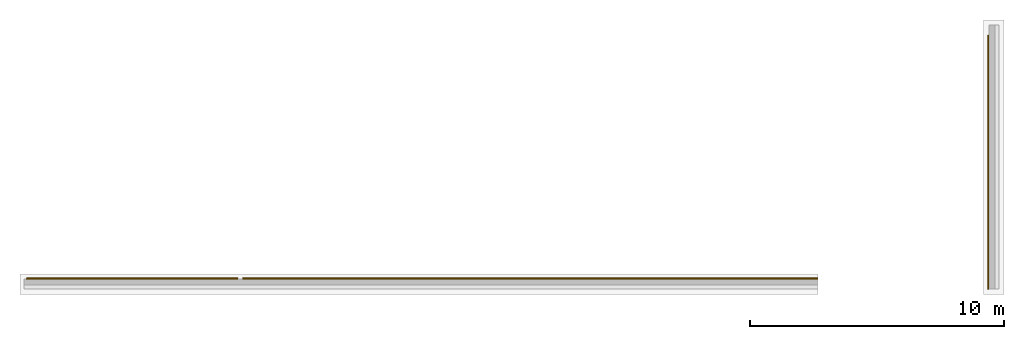
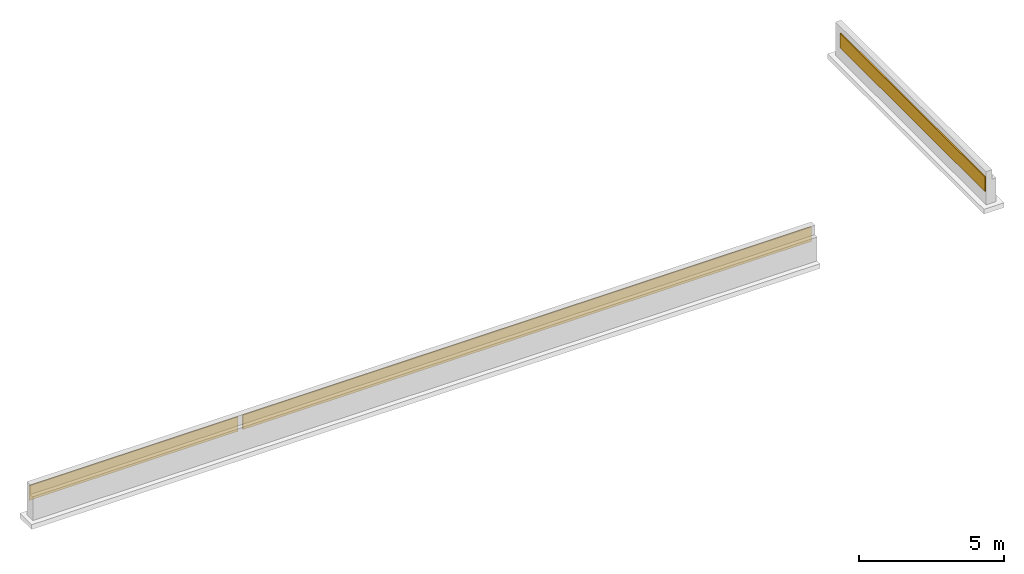
# One storey, part 2 of 2: 3 coverings.
"""IFC4X3_ADD2 building model written with IfcOpenShell, lengths in millimetres."""

from ifc_helpers import new_model, entity, si_unit, converted_unit, frame, origin_with_axes, origin_2d_with_axis, place, context, subcontext, project, spatial, indexed_curve, outline, extrude, clip, halfspace, material, layer, layer_set, layer_usage, type_object, element, save


model = new_model("IFC4X3_ADD2")

# Units and contexts
model_context = context("Model", 3, precision=1e-05, world=origin_with_axes())
plan_context = context("Plan", 2, precision=1e-05, world=origin_2d_with_axis())
body_context = subcontext(model_context, "Body", "Model", "MODEL_VIEW")
ifc_project = project(units=[converted_unit("PLANEANGLEUNIT", "degree", entity("IfcReal", 0.0174532925199433), si_unit("PLANEANGLEUNIT", "RADIAN"), dimensions=[0, 0, 0, 0, 0, 0, 0]), si_unit("AREAUNIT", "SQUARE_METRE", prefix="MILLI"), si_unit("VOLUMEUNIT", "CUBIC_METRE", prefix="MILLI"), si_unit("LENGTHUNIT", "METRE", prefix="MILLI")], contexts=[model_context, plan_context])

# Site, building, storey
site_placement = place(None, frame((0.0, 0.0, -200.000002980232), z_axis=(0.0, 0.0, 1.0), x_axis=(1.0, 0.0, 0.0)))
site = spatial("IfcSite", under=ifc_project, at=site_placement)
building_placement = place(site_placement, frame((0.0, 0.0, 200.000002980232), z_axis=(0.0, 0.0, 1.0), x_axis=(1.0, 0.0, 0.0)))
building = spatial("IfcBuilding", under=site, at=building_placement, Name="001")
storey_placement = place(building_placement, frame((0.0, 0.0, -1400.00009536743), z_axis=(0.0, 0.0, 1.0), x_axis=(1.0, 0.0, 0.0)))
storey = spatial("IfcBuildingStorey", under=building, at=storey_placement, Name="-001 - TOP OF FOOTING")

# Coverings
ifc_material = material(Name="Rigid Insulation", Category="07211 - Rigid Insulation")
ifc_layer = layer(ifc_material, 50.0, Name="Vertical Insulation")
ifc_layer_set = layer_set([ifc_layer])
ifc_layer_usage_1 = layer_usage(ifc_layer_set, "AXIS2", "POSITIVE", 0.0)
covering_type = type_object("IfcCoveringType", PredefinedType="INSULATION", material=ifc_layer_set)
covering_1_placement = place(storey_placement, frame((3230.61680793762, -2707.69953727722, 575.000047683714), z_axis=(0.0, 0.0, 1.0), x_axis=(1.0, 0.0, 0.0)))
element("IfcCovering", 1, at=covering_1_placement, inside=storey, type_object=covering_type, material=ifc_layer_usage_1, Name="VerticalRigidInsulation", PredefinedType="INSULATION", context=body_context, shape_type="Clipping", body=[
    clip(extrude(outline(indexed_curve([(0.0, 0.0), (0.0, 50.0), (8383.5810640513, 50.0), (8383.5810640513, 0.0), (0.0, 0.0)], self_intersect=False)), origin_with_axes(), (0.0, 0.0, 1.0), 610.000014305115), halfspace(frame((49.9999523162842, 0.0, 825.000047683716), z_axis=(-0.923880755901337, 0.382680416107178, 0.0), x_axis=(0.382680425292123, 0.923880778075959, 0.0)), False)),
])
ifc_layer_usage_2 = layer_usage(ifc_layer_set, "AXIS2", "POSITIVE", 0.0)
covering_2_placement = place(storey_placement, frame((41214.7827148438, -3107.6967716217, 575.000047683714), z_axis=(0.0, 0.0, 1.0), x_axis=(3.13916473260163e-07, 0.999999999999951, 0.0)))
element("IfcCovering", 2, at=covering_2_placement, inside=storey, type_object=covering_type, material=ifc_layer_usage_2, Name="BuildingElementPart.012", PredefinedType="INSULATION", context=body_context, shape_type="SweptSolid", body=[
    extrude(outline(indexed_curve([(0.0, 0.0), (0.0, 50.0), (10010.0051419522, 50.0), (10010.0051419522, 0.0), (0.0, 0.0)], self_intersect=False)), origin_with_axes(), (0.0, 0.0, 1.0), 610.000014305115),
])
ifc_layer_usage_3 = layer_usage(ifc_layer_set, "AXIS2", "POSITIVE", 0.0)
covering_3_placement = place(storey_placement, frame((11806.5958023071, -2707.69953727722, 575.000047683714), z_axis=(0.0, 0.0, 1.0), x_axis=(1.0, 0.0, 0.0)))
element("IfcCovering", 3, at=covering_3_placement, inside=storey, type_object=covering_type, material=ifc_layer_usage_3, Name="VerticalRigidInsulation.001", PredefinedType="INSULATION", context=body_context, shape_type="SweptSolid", body=[
    extrude(outline(indexed_curve([(0.0, 0.0), (0.0, 50.0), (22668.2134362332, 50.0), (22668.2134362332, 0.0), (0.0, 0.0)], self_intersect=False)), origin_with_axes(), (0.0, 0.0, 1.0), 610.000014305115),
])

save(model, "model.ifc")
